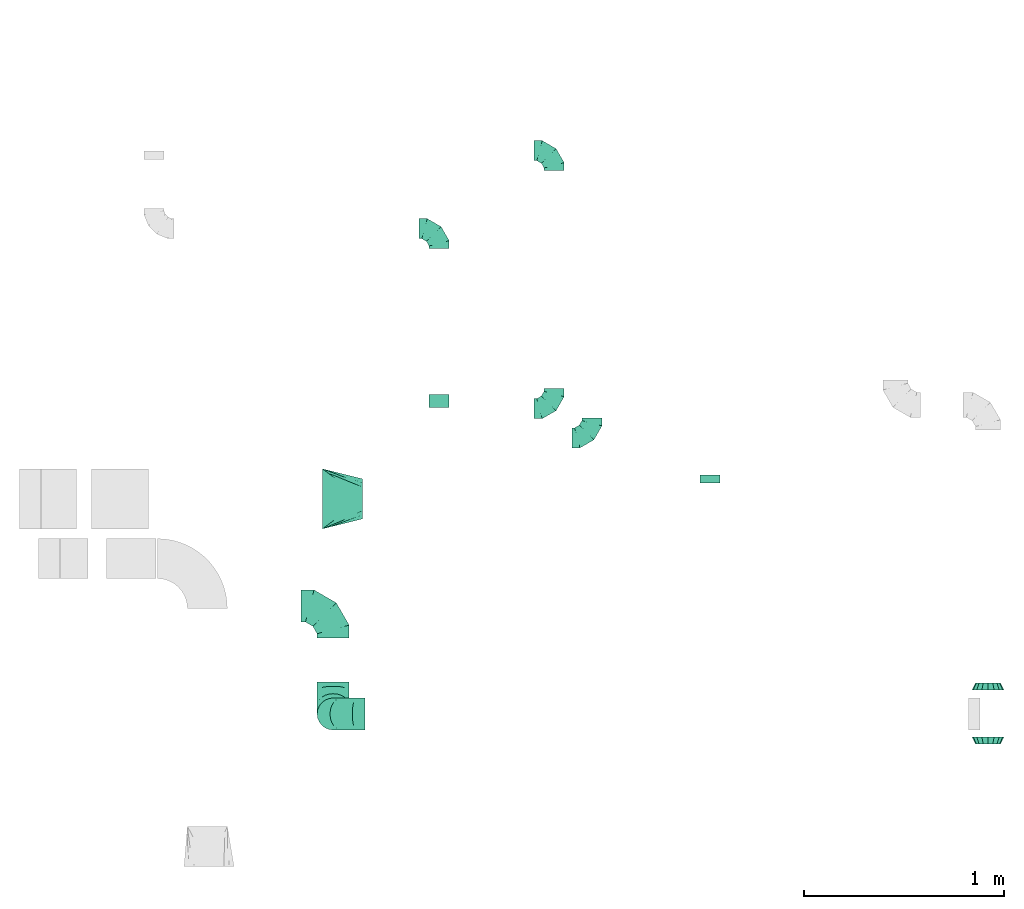
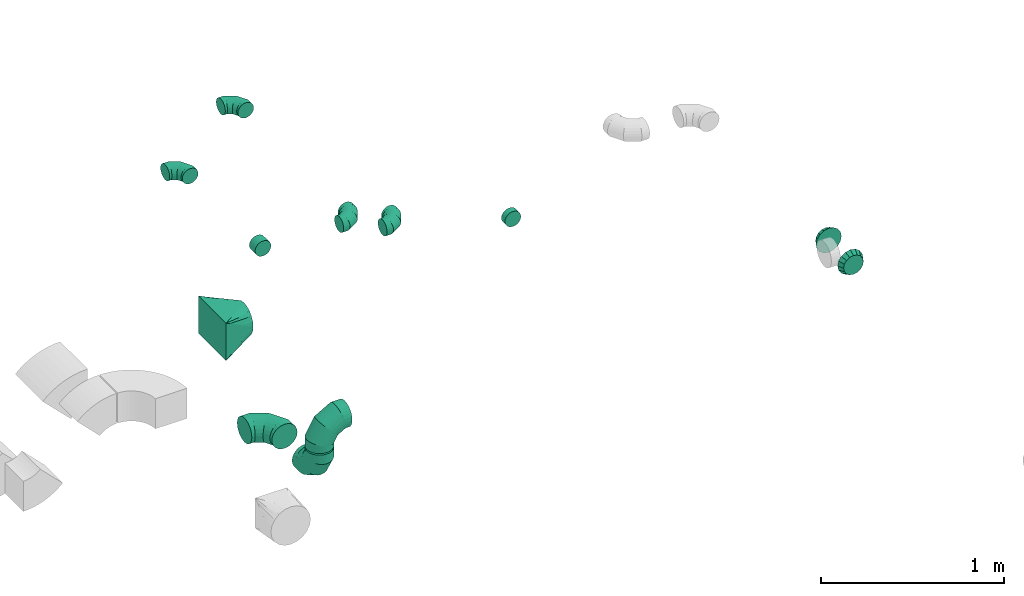
# One storey, part 37 of 44: 12 flow fittings.
"""IFC2X3 building model written with IfcOpenShell, lengths in millimetres."""

from ifc_helpers import new_model, entity, si_unit, converted_unit, derived_unit, direction, frame, origin, place, context, subcontext, project, spatial, faceted_brep, source, transform, mapped, material, type_object, type_shapes, element, save


model = new_model("IFC2X3")

# Units and contexts
model_context = context("Model", 3, precision=0.01, world=origin(), true_north=direction((6.12303176911189e-17, 1.0)))
body_context = subcontext(model_context, "Body", "Model", "MODEL_VIEW")
ifc_project = project(units=[si_unit("LENGTHUNIT", "METRE", prefix="MILLI"), si_unit("AREAUNIT", "SQUARE_METRE"), si_unit("VOLUMEUNIT", "CUBIC_METRE"), converted_unit("PLANEANGLEUNIT", "DEGREE", entity("IfcRatioMeasure", 0.0174532925199433), si_unit("PLANEANGLEUNIT", "RADIAN"), dimensions=[0, 0, 0, 0, 0, 0, 0]), si_unit("MASSUNIT", "GRAM", prefix="KILO"), derived_unit("MASSDENSITYUNIT", [(si_unit("MASSUNIT", "GRAM", prefix="KILO"), 1), (si_unit("LENGTHUNIT", "METRE"), -3)]), derived_unit("MOMENTOFINERTIAUNIT", [(si_unit("LENGTHUNIT", "METRE"), 4)]), si_unit("TIMEUNIT", "SECOND"), si_unit("FREQUENCYUNIT", "HERTZ"), si_unit("THERMODYNAMICTEMPERATUREUNIT", "DEGREE_CELSIUS"), derived_unit("THERMALTRANSMITTANCEUNIT", [(si_unit("MASSUNIT", "GRAM", prefix="KILO"), 1), (si_unit("THERMODYNAMICTEMPERATUREUNIT", "KELVIN"), -1), (si_unit("TIMEUNIT", "SECOND"), -3)]), derived_unit("VOLUMETRICFLOWRATEUNIT", [(si_unit("LENGTHUNIT", "METRE"), 3), (si_unit("TIMEUNIT", "SECOND"), -1)]), derived_unit("MASSFLOWRATEUNIT", [(si_unit("MASSUNIT", "GRAM", prefix="KILO"), 1), (si_unit("TIMEUNIT", "SECOND"), -1)]), derived_unit("ROTATIONALFREQUENCYUNIT", [(si_unit("TIMEUNIT", "SECOND"), -1)]), si_unit("ELECTRICCURRENTUNIT", "AMPERE"), si_unit("ELECTRICVOLTAGEUNIT", "VOLT"), si_unit("POWERUNIT", "WATT"), si_unit("FORCEUNIT", "NEWTON", prefix="KILO"), si_unit("ILLUMINANCEUNIT", "LUX"), si_unit("LUMINOUSFLUXUNIT", "LUMEN"), si_unit("LUMINOUSINTENSITYUNIT", "CANDELA"), derived_unit("USERDEFINED", [(si_unit("MASSUNIT", "GRAM", prefix="KILO"), -1), (si_unit("LENGTHUNIT", "METRE"), -2), (si_unit("TIMEUNIT", "SECOND"), 3), (si_unit("LUMINOUSFLUXUNIT", "LUMEN"), 1)]), derived_unit("LINEARVELOCITYUNIT", [(si_unit("LENGTHUNIT", "METRE"), 1), (si_unit("TIMEUNIT", "SECOND"), -1)]), si_unit("PRESSUREUNIT", "PASCAL"), derived_unit("USERDEFINED", [(si_unit("LENGTHUNIT", "METRE"), -2), (si_unit("MASSUNIT", "GRAM", prefix="KILO"), 1), (si_unit("TIMEUNIT", "SECOND"), -2)]), derived_unit("LINEARFORCEUNIT", [(si_unit("MASSUNIT", "GRAM", prefix="KILO"), 1), (si_unit("LENGTHUNIT", "METRE"), 1), (si_unit("TIMEUNIT", "SECOND"), -2), (si_unit("LENGTHUNIT", "METRE"), -1)]), derived_unit("PLANARFORCEUNIT", [(si_unit("MASSUNIT", "GRAM", prefix="KILO"), 1), (si_unit("LENGTHUNIT", "METRE"), 1), (si_unit("TIMEUNIT", "SECOND"), -2), (si_unit("LENGTHUNIT", "METRE"), -2)])], contexts=[model_context])

# Site, building, storey
site_placement = place(None, origin())
site = spatial("IfcSite", under=ifc_project, at=site_placement, CompositionType="ELEMENT")
building_placement = place(site_placement, origin())
building = spatial("IfcBuilding", under=site, at=building_placement, CompositionType="ELEMENT")
storey_placement = place(building_placement, frame((0.0, 0.0, 15900.0)))
storey = spatial("IfcBuildingStorey", under=building, at=storey_placement, CompositionType="ELEMENT", Elevation=15900.0)

# Flow fittings
ifc_material = material()
duct_fitting_type_1 = type_object("IfcDuctFittingType", PredefinedType="NOTDEFINED", material=ifc_material)
shared_shape_1 = source(origin(), body_context, "Body", "Brep", [
    faceted_brep([(-160.0, 0.0, -80.0), (-160.0, -20.71, -77.27), (-160.0, -40.0, -69.28), (-160.0, -56.57, -56.57), (-160.0, -69.28, -40.0), (-160.0, -77.27, -20.71), (-160.0, -80.0, 0.0), (-160.0, -77.27, 20.71), (-160.0, -69.28, 40.0), (-160.0, -56.57, 56.57), (-160.0, -40.0, 69.28), (-160.0, -20.71, 77.27), (-160.0, 0.0, 80.0), (-160.0, 20.71, 77.27), (-160.0, 40.0, 69.28), (-160.0, 56.57, 56.57), (-160.0, 69.28, 40.0), (-160.0, 77.27, 20.71), (-160.0, 80.0, 0.0), (-160.0, 77.27, -20.71), (-160.0, 69.28, -40.0), (-160.0, 56.57, -56.57), (-160.0, 40.0, -69.28), (-160.0, 20.71, -77.27), (-122.68, 20.71, 77.27), (-127.85, 40.0, 69.28), (-117.13, 0.0, 80.0), (-132.29, 56.57, 56.57), (-137.83, 77.27, 20.71), (-138.56, 80.0, 0.0), (-135.69, 69.28, 40.0), (-135.69, 69.28, -40.0), (-132.29, 56.57, -56.57), (-137.83, 77.27, -20.71), (-122.68, 20.71, -77.27), (-117.13, 0.0, -80.0), (-127.85, 40.0, -69.28), (-111.58, -20.71, -77.27), (-106.41, -40.0, -69.28), (-101.97, -56.57, -56.57), (-98.56, -69.28, -40.0), (-96.42, -77.27, -20.71), (-95.69, -80.0, 0.0), (-96.42, -77.27, 20.71), (-98.56, -69.28, 40.0), (-101.97, -56.57, 56.57), (-106.41, -40.0, 69.28), (-111.58, -20.71, 77.27), (-58.03, 58.03, 77.27), (-72.15, 72.15, 69.28), (-42.87, 42.87, 80.0), (-84.28, 84.28, 56.57), (-93.59, 93.59, 40.0), (-99.44, 99.44, 20.71), (-101.44, 101.44, 0.0), (-99.44, 99.44, -20.71), (-93.59, 93.59, -40.0), (-84.28, 84.28, -56.57), (-58.03, 58.03, -77.27), (-42.87, 42.87, -80.0), (-72.15, 72.15, -69.28), (-27.71, 27.71, -77.27), (-13.59, 13.59, -69.28), (-1.46, 1.46, -56.57), (7.85, -7.85, -40.0), (13.7, -13.7, -20.71), (15.69, -15.69, 0.0), (13.7, -13.7, 20.71), (7.85, -7.85, 40.0), (-1.46, 1.46, 56.57), (-13.59, 13.59, 69.28), (-27.71, 27.71, 77.27), (-20.71, 122.68, 77.27), (-40.0, 127.85, 69.28), (0.0, 117.13, 80.0), (-56.57, 132.29, 56.57), (-69.28, 135.69, 40.0), (-77.27, 137.83, 20.71), (-80.0, 138.56, 0.0), (-77.27, 137.83, -20.71), (-69.28, 135.69, -40.0), (-56.57, 132.29, -56.57), (-20.71, 122.68, -77.27), (0.0, 117.13, -80.0), (-40.0, 127.85, -69.28), (20.71, 111.58, -77.27), (40.0, 106.41, -69.28), (56.57, 101.97, -56.57), (69.28, 98.56, -40.0), (77.27, 96.42, -20.71), (80.0, 95.69, 0.0), (77.27, 96.42, 20.71), (69.28, 98.56, 40.0), (56.57, 101.97, 56.57), (40.0, 106.41, 69.28), (20.71, 111.58, 77.27), (-20.71, 160.0, -77.27), (-40.0, 160.0, -69.28), (-56.57, 160.0, -56.57), (-69.28, 160.0, -40.0), (-77.27, 160.0, -20.71), (-80.0, 160.0, 0.0), (-77.27, 160.0, 20.71), (-69.28, 160.0, 40.0), (-56.57, 160.0, 56.57), (-40.0, 160.0, 69.28), (-20.71, 160.0, 77.27), (0.0, 160.0, 80.0), (20.71, 160.0, 77.27), (40.0, 160.0, 69.28), (56.57, 160.0, 56.57), (69.28, 160.0, 40.0), (77.27, 160.0, 20.71), (80.0, 160.0, 0.0), (77.27, 160.0, -20.71), (69.28, 160.0, -40.0), (56.57, 160.0, -56.57), (40.0, 160.0, -69.28), (20.71, 160.0, -77.27), (0.0, 160.0, -80.0)], [[[0, 1, 2, 3, 4, 5, 6, 7, 8, 9, 10, 11, 12, 13, 14, 15, 16, 17, 18, 19, 20, 21, 22, 23]], [[24, 25, 14, 13]], [[26, 24, 13, 12]], [[14, 25, 27, 15]], [[28, 29, 18, 17]], [[30, 28, 17, 16]], [[15, 27, 30, 16]], [[20, 31, 32, 21]], [[33, 31, 20, 19]], [[18, 29, 33, 19]], [[34, 35, 0, 23]], [[36, 34, 23, 22]], [[32, 36, 22, 21]], [[1, 0, 35, 37]], [[2, 1, 37, 38]], [[3, 2, 38, 39]], [[5, 4, 40, 41]], [[6, 5, 41, 42]], [[39, 40, 4, 3]], [[6, 42, 43, 7]], [[7, 43, 44, 8]], [[8, 44, 45, 9]], [[9, 45, 46, 10]], [[10, 46, 47, 11]], [[26, 12, 11, 47]], [[48, 49, 25, 24]], [[50, 48, 24, 26]], [[27, 25, 49, 51]], [[52, 53, 28, 30]], [[51, 52, 30, 27]], [[29, 28, 53, 54]], [[55, 56, 31, 33]], [[54, 55, 33, 29]], [[32, 31, 56, 57]], [[58, 59, 35, 34]], [[60, 58, 34, 36]], [[57, 60, 36, 32]], [[37, 35, 59, 61]], [[38, 37, 61, 62]], [[39, 38, 62, 63]], [[41, 40, 64, 65]], [[42, 41, 65, 66]], [[63, 64, 40, 39]], [[43, 42, 66, 67]], [[44, 43, 67, 68]], [[68, 69, 45, 44]], [[46, 45, 69, 70]], [[47, 46, 70, 71]], [[26, 47, 71, 50]], [[72, 73, 49, 48]], [[74, 72, 48, 50]], [[51, 49, 73, 75]], [[76, 77, 53, 52]], [[75, 76, 52, 51]], [[54, 53, 77, 78]], [[79, 80, 56, 55]], [[78, 79, 55, 54]], [[57, 56, 80, 81]], [[82, 83, 59, 58]], [[84, 82, 58, 60]], [[81, 84, 60, 57]], [[61, 59, 83, 85]], [[62, 61, 85, 86]], [[63, 62, 86, 87]], [[65, 64, 88, 89]], [[66, 65, 89, 90]], [[87, 88, 64, 63]], [[67, 66, 90, 91]], [[68, 67, 91, 92]], [[92, 93, 69, 68]], [[70, 69, 93, 94]], [[71, 70, 94, 95]], [[50, 71, 95, 74]], [[96, 97, 98, 99, 100, 101, 102, 103, 104, 105, 106, 107, 108, 109, 110, 111, 112, 113, 114, 115, 116, 117, 118, 119]], [[72, 74, 107, 106]], [[73, 72, 106, 105]], [[75, 73, 105, 104]], [[77, 76, 103, 102]], [[78, 77, 102, 101]], [[75, 104, 103, 76]], [[78, 101, 100, 79]], [[79, 100, 99, 80]], [[80, 99, 98, 81]], [[84, 97, 96, 82]], [[82, 96, 119, 83]], [[84, 81, 98, 97]], [[118, 117, 86, 85]], [[119, 118, 85, 83]], [[116, 87, 86, 117]], [[88, 115, 114, 89]], [[89, 114, 113, 90]], [[115, 88, 87, 116]], [[112, 111, 92, 91]], [[113, 112, 91, 90]], [[111, 110, 93, 92]], [[95, 94, 109, 108]], [[74, 95, 108, 107]], [[110, 109, 94, 93]]]),
])
type_shapes(duct_fitting_type_1, [shared_shape_1])
for number, where, z_axis, x_axis in (
    (1, (69509.84, 9338.57, 2935.0), (0.0, 0.0, 1.0), (0.0, 1.0, 0.0)),
    (2, (69509.84, 8798.57, 2935.0), (-1.0, 0.0, 0.0), (0.0, -1.0, 0.0)),
    (3, (69509.84, 8798.57, 3265.0), (0.0, 1.0, 0.0), (0.0, 0.0, 1.0)),
):
    element("IfcFlowFitting", number, at=place(storey_placement, frame(where, z_axis=z_axis, x_axis=x_axis)), inside=storey, type_object=duct_fitting_type_1, material=ifc_material, context=body_context, shape_type="MappedRepresentation", body=[
        mapped(shared_shape_1, transform((0.0, 0.0, 0.0), scale=1.0)),
    ])
duct_fitting_type_2 = type_object("IfcDuctFittingType", PredefinedType="NOTDEFINED", material=ifc_material)
shared_shape_2 = source(origin(), body_context, "Body", "Brep", [
    faceted_brep([(-100.0, 0.0, -50.0), (-100.0, -12.94, -48.3), (-100.0, -25.0, -43.3), (-100.0, -35.36, -35.36), (-100.0, -43.3, -25.0), (-100.0, -48.3, -12.94), (-100.0, -50.0, 0.0), (-100.0, -48.3, 12.94), (-100.0, -43.3, 25.0), (-100.0, -35.36, 35.36), (-100.0, -25.0, 43.3), (-100.0, -12.94, 48.3), (-100.0, 0.0, 50.0), (-100.0, 12.94, 48.3), (-100.0, 25.0, 43.3), (-100.0, 35.36, 35.36), (-100.0, 43.3, 25.0), (-100.0, 48.3, 12.94), (-100.0, 50.0, 0.0), (-100.0, 48.3, -12.94), (-100.0, 43.3, -25.0), (-100.0, 35.36, -35.36), (-100.0, 25.0, -43.3), (-100.0, 12.94, -48.3), (-76.67, 12.94, 48.3), (-79.9, 25.0, 43.3), (-73.21, 0.0, 50.0), (-82.68, 35.36, 35.36), (-86.15, 48.3, 12.94), (-86.6, 50.0, 0.0), (-84.81, 43.3, 25.0), (-84.81, 43.3, -25.0), (-82.68, 35.36, -35.36), (-86.15, 48.3, -12.94), (-76.67, 12.94, -48.3), (-73.21, 0.0, -50.0), (-79.9, 25.0, -43.3), (-69.74, -12.94, -48.3), (-66.51, -25.0, -43.3), (-63.73, -35.36, -35.36), (-61.6, -43.3, -25.0), (-60.26, -48.3, -12.94), (-59.81, -50.0, 0.0), (-60.26, -48.3, 12.94), (-61.6, -43.3, 25.0), (-63.73, -35.36, 35.36), (-66.51, -25.0, 43.3), (-69.74, -12.94, 48.3), (-36.27, 36.27, 48.3), (-45.1, 45.1, 43.3), (-26.79, 26.79, 50.0), (-52.68, 52.68, 35.36), (-58.49, 58.49, 25.0), (-62.15, 62.15, 12.94), (-63.4, 63.4, 0.0), (-62.15, 62.15, -12.94), (-58.49, 58.49, -25.0), (-52.68, 52.68, -35.36), (-36.27, 36.27, -48.3), (-26.79, 26.79, -50.0), (-45.1, 45.1, -43.3), (-17.32, 17.32, -48.3), (-8.49, 8.49, -43.3), (-0.91, 0.91, -35.36), (4.9, -4.9, -25.0), (8.56, -8.56, -12.94), (9.81, -9.81, 0.0), (8.56, -8.56, 12.94), (4.9, -4.9, 25.0), (-0.91, 0.91, 35.36), (-8.49, 8.49, 43.3), (-17.32, 17.32, 48.3), (-12.94, 76.67, 48.3), (-25.0, 79.9, 43.3), (0.0, 73.21, 50.0), (-35.36, 82.68, 35.36), (-43.3, 84.81, 25.0), (-48.3, 86.15, 12.94), (-50.0, 86.6, 0.0), (-48.3, 86.15, -12.94), (-43.3, 84.81, -25.0), (-35.36, 82.68, -35.36), (-12.94, 76.67, -48.3), (0.0, 73.21, -50.0), (-25.0, 79.9, -43.3), (12.94, 69.74, -48.3), (25.0, 66.51, -43.3), (35.36, 63.73, -35.36), (43.3, 61.6, -25.0), (48.3, 60.26, -12.94), (50.0, 59.81, 0.0), (48.3, 60.26, 12.94), (43.3, 61.6, 25.0), (35.36, 63.73, 35.36), (25.0, 66.51, 43.3), (12.94, 69.74, 48.3), (-12.94, 100.0, -48.3), (-25.0, 100.0, -43.3), (-35.36, 100.0, -35.36), (-43.3, 100.0, -25.0), (-48.3, 100.0, -12.94), (-50.0, 100.0, 0.0), (-48.3, 100.0, 12.94), (-43.3, 100.0, 25.0), (-35.36, 100.0, 35.36), (-25.0, 100.0, 43.3), (-12.94, 100.0, 48.3), (0.0, 100.0, 50.0), (12.94, 100.0, 48.3), (25.0, 100.0, 43.3), (35.36, 100.0, 35.36), (43.3, 100.0, 25.0), (48.3, 100.0, 12.94), (50.0, 100.0, 0.0), (48.3, 100.0, -12.94), (43.3, 100.0, -25.0), (35.36, 100.0, -35.36), (25.0, 100.0, -43.3), (12.94, 100.0, -48.3), (0.0, 100.0, -50.0)], [[[0, 1, 2, 3, 4, 5, 6, 7, 8, 9, 10, 11, 12, 13, 14, 15, 16, 17, 18, 19, 20, 21, 22, 23]], [[24, 25, 14, 13]], [[26, 24, 13, 12]], [[14, 25, 27, 15]], [[28, 29, 18, 17]], [[30, 28, 17, 16]], [[15, 27, 30, 16]], [[20, 31, 32, 21]], [[33, 31, 20, 19]], [[18, 29, 33, 19]], [[34, 35, 0, 23]], [[36, 34, 23, 22]], [[32, 36, 22, 21]], [[2, 1, 37, 38]], [[3, 2, 38, 39]], [[0, 35, 37, 1]], [[5, 4, 40, 41]], [[6, 5, 41, 42]], [[3, 39, 40, 4]], [[6, 42, 43, 7]], [[7, 43, 44, 8]], [[8, 44, 45, 9]], [[10, 46, 47, 11]], [[11, 47, 26, 12]], [[10, 9, 45, 46]], [[48, 49, 25, 24]], [[50, 48, 24, 26]], [[27, 25, 49, 51]], [[52, 53, 28, 30]], [[51, 52, 30, 27]], [[29, 28, 53, 54]], [[55, 56, 31, 33]], [[54, 55, 33, 29]], [[57, 32, 31, 56]], [[58, 59, 35, 34]], [[60, 58, 34, 36]], [[57, 60, 36, 32]], [[37, 35, 59, 61]], [[38, 37, 61, 62]], [[39, 38, 62, 63]], [[41, 40, 64, 65]], [[42, 41, 65, 66]], [[63, 64, 40, 39]], [[43, 42, 66, 67]], [[44, 43, 67, 68]], [[68, 69, 45, 44]], [[46, 45, 69, 70]], [[47, 46, 70, 71]], [[26, 47, 71, 50]], [[72, 73, 49, 48]], [[74, 72, 48, 50]], [[51, 49, 73, 75]], [[76, 77, 53, 52]], [[75, 76, 52, 51]], [[54, 53, 77, 78]], [[79, 80, 56, 55]], [[78, 79, 55, 54]], [[81, 57, 56, 80]], [[82, 83, 59, 58]], [[84, 82, 58, 60]], [[81, 84, 60, 57]], [[61, 59, 83, 85]], [[62, 61, 85, 86]], [[63, 62, 86, 87]], [[65, 64, 88, 89]], [[66, 65, 89, 90]], [[87, 88, 64, 63]], [[67, 66, 90, 91]], [[68, 67, 91, 92]], [[92, 93, 69, 68]], [[70, 69, 93, 94]], [[71, 70, 94, 95]], [[50, 71, 95, 74]], [[96, 97, 98, 99, 100, 101, 102, 103, 104, 105, 106, 107, 108, 109, 110, 111, 112, 113, 114, 115, 116, 117, 118, 119]], [[72, 74, 107, 106]], [[73, 72, 106, 105]], [[75, 73, 105, 104]], [[77, 76, 103, 102]], [[78, 77, 102, 101]], [[75, 104, 103, 76]], [[78, 101, 100, 79]], [[79, 100, 99, 80]], [[80, 99, 98, 81]], [[96, 119, 83, 82]], [[97, 96, 82, 84]], [[84, 81, 98, 97]], [[83, 119, 118, 85]], [[85, 118, 117, 86]], [[86, 117, 116, 87]], [[88, 115, 114, 89]], [[89, 114, 113, 90]], [[87, 116, 115, 88]], [[91, 90, 113, 112]], [[92, 91, 112, 111]], [[93, 92, 111, 110]], [[95, 94, 109, 108]], [[74, 95, 108, 107]], [[110, 109, 94, 93]]]),
])
type_shapes(duct_fitting_type_2, [shared_shape_2])
for number, where in (
    (4, (70803.81, 10179.05, 3300.0)),
    (5, (70614.82, 10325.19, 3300.0)),
):
    element("IfcFlowFitting", number, at=place(storey_placement, frame(where)), inside=storey, type_object=duct_fitting_type_2, material=ifc_material, context=body_context, shape_type="MappedRepresentation", body=[
        mapped(shared_shape_2, transform((0.0, 0.0, 0.0), scale=1.0)),
    ])
for number, where, z_axis, x_axis in (
    (6, (70614.82, 11615.19, 3300.0), (0.0, 0.0, 1.0), (0.0, 1.0, 0.0)),
    (7, (70039.82, 11225.19, 3300.0), (0.0, 0.0, 1.0), (0.0, 1.0, 0.0)),
):
    element("IfcFlowFitting", number, at=place(storey_placement, frame(where, z_axis=z_axis, x_axis=x_axis)), inside=storey, type_object=duct_fitting_type_2, material=ifc_material, context=body_context, shape_type="MappedRepresentation", body=[
        mapped(shared_shape_2, transform((0.0, 0.0, 0.0), scale=1.0)),
    ])
duct_fitting_type_3 = type_object("IfcDuctFittingType", PredefinedType="NOTDEFINED", material=ifc_material)
shared_shape_3 = source(origin(), body_context, "Body", "Brep", [
    faceted_brep([(35.0, -57.74, 23.92), (35.0, -60.12, 11.96), (35.0, -62.5, 0.0), (35.0, -60.12, -11.96), (35.0, -57.74, -23.92), (35.0, -50.97, -34.06), (35.0, -44.19, -44.19), (35.0, -34.06, -50.97), (35.0, -23.92, -57.74), (35.0, -11.96, -60.12), (35.0, 0.0, -62.5), (35.0, 11.96, -60.12), (35.0, 23.92, -57.74), (35.0, 34.06, -50.97), (35.0, 44.19, -44.19), (35.0, 50.97, -34.06), (35.0, 57.74, -23.92), (35.0, 60.12, -11.96), (35.0, 62.5, 0.0), (35.0, 60.12, 11.96), (35.0, 57.74, 23.92), (35.0, 50.97, 34.06), (35.0, 44.19, 44.19), (35.0, 34.06, 50.97), (35.0, 23.92, 57.74), (35.0, 11.96, 60.12), (35.0, 0.0, 62.5), (35.0, -11.96, 60.12), (35.0, -23.92, 57.74), (35.0, -34.06, 50.97), (35.0, -44.19, 44.19), (35.0, -50.97, 34.06), (0.0, -80.0, 0.0), (0.0, -77.45, 12.81), (0.0, -73.91, 30.61), (0.0, -65.24, 43.59), (0.0, -56.57, 56.57), (0.0, -43.59, 65.24), (0.0, -30.61, 73.91), (0.0, -12.81, 77.45), (0.0, 0.0, 80.0), (0.0, 12.81, 77.45), (0.0, 30.61, 73.91), (0.0, 43.59, 65.24), (0.0, 56.57, 56.57), (0.0, 65.24, 43.59), (0.0, 73.91, 30.61), (0.0, 77.45, 12.81), (0.0, 80.0, 0.0), (0.0, 77.45, -12.81), (0.0, 73.91, -30.61), (0.0, 65.24, -43.59), (0.0, 56.57, -56.57), (0.0, 43.59, -65.24), (0.0, 30.61, -73.91), (0.0, 12.81, -77.45), (0.0, 0.0, -80.0), (0.0, -12.81, -77.45), (0.0, -30.61, -73.91), (0.0, -43.59, -65.24), (0.0, -56.57, -56.57), (0.0, -65.24, -43.59), (0.0, -73.91, -30.61), (0.0, -77.45, -12.81)], [[[0, 1, 2, 3, 4, 5, 6, 7, 8, 9, 10, 11, 12, 13, 14, 15, 16, 17, 18, 19, 20, 21, 22, 23, 24, 25, 26, 27, 28, 29, 30, 31]], [[32, 33, 34, 35, 36, 37, 38, 39, 40, 41, 42, 43, 44, 45, 46, 47, 48, 49, 50, 51, 52, 53, 54, 55, 56, 57, 58, 59, 60, 61, 62, 63]], [[24, 23, 22, 44, 43, 42]], [[20, 46, 45, 44, 22, 21]], [[42, 41, 40, 26, 25, 24]], [[47, 46, 20, 19, 18, 48]], [[0, 31, 30, 36, 35, 34]], [[28, 38, 37, 36, 30, 29]], [[34, 33, 32, 2, 1, 0]], [[39, 38, 28, 27, 26, 40]], [[8, 7, 6, 60, 59, 58]], [[4, 62, 61, 60, 6, 5]], [[58, 57, 56, 10, 9, 8]], [[63, 62, 4, 3, 2, 32]], [[16, 15, 14, 52, 51, 50]], [[12, 54, 53, 52, 14, 13]], [[50, 49, 48, 18, 17, 16]], [[55, 54, 12, 11, 10, 56]]]),
])
type_shapes(duct_fitting_type_3, [shared_shape_3])
for number, where, z_axis, x_axis in (
    (8, (72784.16, 8918.57, 3250.0), (0.0, 0.0, 1.0), (0.0, 1.0, 0.0)),
    (9, (72784.16, 8683.57, 3250.0), (0.0, 0.0, 1.0), (0.0, -1.0, 0.0)),
):
    element("IfcFlowFitting", number, at=place(storey_placement, frame(where, z_axis=z_axis, x_axis=x_axis)), inside=storey, type_object=duct_fitting_type_3, material=ifc_material, context=body_context, shape_type="MappedRepresentation", body=[
        mapped(shared_shape_3, transform((0.0, 0.0, 0.0), scale=1.0)),
    ])
duct_fitting_type_4 = type_object("IfcDuctFittingType", PredefinedType="NOTDEFINED", material=ifc_material)
shared_shape_4 = source(origin(), body_context, "Body", "Brep", [
    faceted_brep([(20.0, 0.0, -50.0), (20.0, 12.94, -48.3), (20.0, 25.0, -43.3), (20.0, 35.36, -35.36), (20.0, 43.3, -25.0), (20.0, 48.3, -12.94), (20.0, 50.0, 0.0), (20.0, 48.3, 12.94), (20.0, 43.3, 25.0), (20.0, 35.36, 35.36), (20.0, 25.0, 43.3), (20.0, 12.94, 48.3), (20.0, 0.0, 50.0), (20.0, -12.94, 48.3), (20.0, -25.0, 43.3), (20.0, -35.36, 35.36), (20.0, -43.3, 25.0), (20.0, -48.3, 12.94), (20.0, -50.0, 0.0), (20.0, -48.3, -12.94), (20.0, -43.3, -25.0), (20.0, -35.36, -35.36), (20.0, -25.0, -43.3), (20.0, -12.94, -48.3), (0.0, 0.0, 50.0), (-43.9, 0.0, 50.0), (-43.9, -12.94, 48.3), (0.0, -12.94, 48.3), (-43.9, -25.0, 43.3), (0.0, -25.0, 43.3), (0.0, -35.36, 35.36), (-43.9, -35.36, 35.36), (0.0, -43.3, 25.0), (-43.9, -43.3, 25.0), (-43.9, -48.3, 12.94), (0.0, -48.3, 12.94), (-43.9, -50.0, 0.0), (0.0, -50.0, 0.0), (-43.9, -48.3, -12.94), (0.0, -48.3, -12.94), (-43.9, -43.3, -25.0), (0.0, -43.3, -25.0), (0.0, -35.36, -35.36), (-43.9, -35.36, -35.36), (0.0, -25.0, -43.3), (-43.9, -25.0, -43.3), (-43.9, -12.94, -48.3), (0.0, -12.94, -48.3), (-43.9, 0.0, -50.0), (0.0, 0.0, -50.0), (-43.9, 12.94, -48.3), (0.0, 12.94, -48.3), (-43.9, 25.0, -43.3), (0.0, 25.0, -43.3), (0.0, 35.36, -35.36), (-43.9, 35.36, -35.36), (0.0, 43.3, -25.0), (-43.9, 43.3, -25.0), (-43.9, 48.3, -12.94), (0.0, 48.3, -12.94), (-43.9, 50.0, 0.0), (0.0, 50.0, 0.0), (-43.9, 48.3, 12.94), (0.0, 48.3, 12.94), (-43.9, 43.3, 25.0), (0.0, 43.3, 25.0), (0.0, 35.36, 35.36), (-43.9, 35.36, 35.36), (0.0, 25.0, 43.3), (-43.9, 25.0, 43.3), (-43.9, 12.94, 48.3), (0.0, 12.94, 48.3)], [[[0, 1, 2, 3, 4, 5, 6, 7, 8, 9, 10, 11, 12, 13, 14, 15, 16, 17, 18, 19, 20, 21, 22, 23]], [[13, 12, 24, 25, 26, 27]], [[14, 13, 27, 26, 28, 29]], [[30, 15, 14, 29, 28, 31]], [[17, 16, 32, 33, 34, 35]], [[18, 17, 35, 34, 36, 37]], [[32, 16, 15, 30, 31, 33]], [[19, 18, 37, 36, 38, 39]], [[20, 19, 39, 38, 40, 41]], [[42, 21, 20, 41, 40, 43]], [[23, 22, 44, 45, 46, 47]], [[0, 23, 47, 46, 48, 49]], [[44, 22, 21, 42, 43, 45]], [[1, 0, 49, 48, 50, 51]], [[2, 1, 51, 50, 52, 53]], [[54, 3, 2, 53, 52, 55]], [[5, 4, 56, 57, 58, 59]], [[6, 5, 59, 58, 60, 61]], [[56, 4, 3, 54, 55, 57]], [[7, 6, 61, 60, 62, 63]], [[8, 7, 63, 62, 64, 65]], [[66, 9, 8, 65, 64, 67]], [[11, 10, 68, 69, 70, 71]], [[12, 11, 71, 70, 25, 24]], [[68, 10, 9, 66, 67, 69]], [[46, 45, 43, 40, 38, 36, 34, 33, 31, 28, 26, 25, 70, 69, 67, 64, 62, 60, 58, 57, 55, 52, 50, 48]]]),
])
type_shapes(duct_fitting_type_4, [shared_shape_4])
flow_fitting_1_placement = place(storey_placement, frame((70039.82, 10375.19, 3300.0), z_axis=(0.0, 0.0, -1.0), x_axis=(0.0, 1.0, 0.0)))
element("IfcFlowFitting", 10, at=flow_fitting_1_placement, inside=storey, type_object=duct_fitting_type_4, material=ifc_material, context=body_context, shape_type="MappedRepresentation", body=[
    mapped(shared_shape_4, transform((0.0, 0.0, 0.0), scale=1.0)),
])
duct_fitting_type_5 = type_object("IfcDuctFittingType", PredefinedType="NOTDEFINED", material=ifc_material)
shared_shape_5 = source(origin(), body_context, "Body", "Brep", [
    faceted_brep([(20.0, 0.0, -50.0), (20.0, 12.94, -48.3), (20.0, 25.0, -43.3), (20.0, 35.36, -35.36), (20.0, 43.3, -25.0), (20.0, 48.3, -12.94), (20.0, 50.0, 0.0), (20.0, 48.3, 12.94), (20.0, 43.3, 25.0), (20.0, 35.36, 35.36), (20.0, 25.0, 43.3), (20.0, 12.94, 48.3), (20.0, 0.0, 50.0), (20.0, -12.94, 48.3), (20.0, -25.0, 43.3), (20.0, -35.36, 35.36), (20.0, -43.3, 25.0), (20.0, -48.3, 12.94), (20.0, -50.0, 0.0), (20.0, -48.3, -12.94), (20.0, -43.3, -25.0), (20.0, -35.36, -35.36), (20.0, -25.0, -43.3), (20.0, -12.94, -48.3), (0.0, 0.0, 50.0), (-19.49, 0.0, 50.0), (-19.49, -12.94, 48.3), (0.0, -12.94, 48.3), (-19.49, -25.0, 43.3), (0.0, -25.0, 43.3), (0.0, -35.36, 35.36), (-19.49, -35.36, 35.36), (0.0, -43.3, 25.0), (-19.49, -43.3, 25.0), (-19.49, -48.3, 12.94), (0.0, -48.3, 12.94), (-19.49, -50.0, 0.0), (0.0, -50.0, 0.0), (-19.49, -48.3, -12.94), (0.0, -48.3, -12.94), (-19.49, -43.3, -25.0), (0.0, -43.3, -25.0), (0.0, -35.36, -35.36), (-19.49, -35.36, -35.36), (0.0, -25.0, -43.3), (-19.49, -25.0, -43.3), (-19.49, -12.94, -48.3), (0.0, -12.94, -48.3), (-19.49, 0.0, -50.0), (0.0, 0.0, -50.0), (-19.49, 12.94, -48.3), (0.0, 12.94, -48.3), (-19.49, 25.0, -43.3), (0.0, 25.0, -43.3), (0.0, 35.36, -35.36), (-19.49, 35.36, -35.36), (0.0, 43.3, -25.0), (-19.49, 43.3, -25.0), (-19.49, 48.3, -12.94), (0.0, 48.3, -12.94), (-19.49, 50.0, 0.0), (0.0, 50.0, 0.0), (-19.49, 48.3, 12.94), (0.0, 48.3, 12.94), (-19.49, 43.3, 25.0), (0.0, 43.3, 25.0), (0.0, 35.36, 35.36), (-19.49, 35.36, 35.36), (0.0, 25.0, 43.3), (-19.49, 25.0, 43.3), (-19.49, 12.94, 48.3), (0.0, 12.94, 48.3)], [[[0, 1, 2, 3, 4, 5, 6, 7, 8, 9, 10, 11, 12, 13, 14, 15, 16, 17, 18, 19, 20, 21, 22, 23]], [[13, 12, 24, 25, 26, 27]], [[14, 13, 27, 26, 28, 29]], [[30, 15, 14, 29, 28, 31]], [[17, 16, 32, 33, 34, 35]], [[18, 17, 35, 34, 36, 37]], [[32, 16, 15, 30, 31, 33]], [[19, 18, 37, 36, 38, 39]], [[20, 19, 39, 38, 40, 41]], [[42, 21, 20, 41, 40, 43]], [[23, 22, 44, 45, 46, 47]], [[0, 23, 47, 46, 48, 49]], [[44, 22, 21, 42, 43, 45]], [[1, 0, 49, 48, 50, 51]], [[2, 1, 51, 50, 52, 53]], [[54, 3, 2, 53, 52, 55]], [[5, 4, 56, 57, 58, 59]], [[6, 5, 59, 58, 60, 61]], [[56, 4, 3, 54, 55, 57]], [[7, 6, 61, 60, 62, 63]], [[8, 7, 63, 62, 64, 65]], [[66, 9, 8, 65, 64, 67]], [[11, 10, 68, 69, 70, 71]], [[12, 11, 71, 70, 25, 24]], [[68, 10, 9, 66, 67, 69]], [[46, 45, 43, 40, 38, 36, 34, 33, 31, 28, 26, 25, 70, 69, 67, 64, 62, 60, 58, 57, 55, 52, 50, 48]]]),
])
type_shapes(duct_fitting_type_5, [shared_shape_5])
flow_fitting_2_placement = place(storey_placement, frame((71394.92, 9974.07, 3250.0), z_axis=(0.0, 0.0, -1.0), x_axis=(0.0, 1.0, 0.0)))
element("IfcFlowFitting", 11, at=flow_fitting_2_placement, inside=storey, type_object=duct_fitting_type_5, material=ifc_material, context=body_context, shape_type="MappedRepresentation", body=[
    mapped(shared_shape_5, transform((0.0, 0.0, 0.0), scale=1.0)),
])
duct_fitting_type_6 = type_object("IfcDuctFittingType", PredefinedType="NOTDEFINED", material=ifc_material)
shared_shape_6 = source(origin(), body_context, "Body", "Brep", [
    faceted_brep([(200.0, 30.9, 95.11), (200.0, 19.08, 96.98), (200.0, 9.54, 98.49), (200.0, 4.77, 99.24), (200.0, 0.0, 100.0), (200.0, -4.77, 99.24), (200.0, -9.54, 98.49), (200.0, -19.08, 96.98), (200.0, -30.9, 95.11), (200.0, -44.84, 88.0), (200.0, -58.78, 80.9), (200.0, -69.84, 69.84), (200.0, -80.9, 58.78), (200.0, -88.0, 44.84), (200.0, -95.11, 30.9), (200.0, -96.98, 19.08), (200.0, -98.49, 9.54), (200.0, -99.24, 4.77), (200.0, -100.0, 0.0), (200.0, -99.24, -4.77), (200.0, -98.49, -9.54), (200.0, -96.98, -19.08), (200.0, -95.11, -30.9), (200.0, -88.0, -44.84), (200.0, -80.9, -58.78), (200.0, -69.84, -69.84), (200.0, -58.78, -80.9), (200.0, -44.84, -88.0), (200.0, -30.9, -95.11), (200.0, -19.08, -96.98), (200.0, -9.54, -98.49), (200.0, -4.77, -99.24), (200.0, 0.0, -100.0), (200.0, 4.77, -99.24), (200.0, 9.54, -98.49), (200.0, 19.08, -96.98), (200.0, 30.9, -95.11), (200.0, 44.84, -88.0), (200.0, 58.78, -80.9), (200.0, 69.84, -69.84), (200.0, 80.9, -58.78), (200.0, 88.0, -44.84), (200.0, 95.11, -30.9), (200.0, 96.98, -19.08), (200.0, 98.49, -9.54), (200.0, 99.24, -4.77), (200.0, 100.0, 0.0), (200.0, 99.24, 4.77), (200.0, 98.49, 9.54), (200.0, 96.98, 19.08), (200.0, 95.11, 30.9), (200.0, 88.0, 44.84), (200.0, 80.9, 58.78), (200.0, 69.84, 69.84), (200.0, 58.78, 80.9), (200.0, 44.84, 88.0), (0.0, -150.0, 125.0), (0.0, 150.0, 125.0), (0.0, 150.0, -125.0), (0.0, -150.0, -125.0), (104.11, -71.91, 111.99), (100.0, -108.15, 99.93), (26.03, -130.48, 121.75), (78.09, -91.44, 115.24), (52.06, -110.96, 118.49), (188.01, -8.99, 101.5), (176.03, -17.98, 103.0), (152.06, -35.96, 105.99), (128.09, -53.94, 108.99), (52.06, -136.99, 92.46), (78.09, -130.48, 76.2), (104.11, -123.97, 59.93), (128.09, -117.98, 44.95), (152.06, -111.99, 29.96), (176.03, -105.99, 14.98), (188.01, -103.0, 7.49), (26.03, -143.49, 108.73), (26.03, -143.49, -108.73), (52.06, -136.99, -92.46), (78.09, -130.48, -76.2), (104.11, -123.97, -59.93), (128.09, -117.98, -44.95), (152.06, -111.99, -29.96), (176.03, -105.99, -14.98), (188.01, -103.0, -7.49), (100.0, -112.43, -95.65), (52.06, -110.96, -118.49), (78.09, -91.44, -115.24), (104.11, -71.91, -111.99), (128.09, -53.94, -108.99), (152.06, -35.96, -105.99), (176.03, -17.98, -103.0), (188.01, -8.99, -101.5), (26.03, -130.48, -121.75), (26.03, 130.48, -121.75), (52.06, 110.96, -118.49), (78.09, 91.44, -115.24), (104.11, 71.91, -111.99), (128.09, 53.94, -108.99), (152.06, 35.96, -105.99), (176.03, 17.98, -103.0), (188.01, 8.99, -101.5), (100.0, 108.15, -99.93), (52.06, 136.99, -92.46), (78.09, 130.48, -76.2), (104.11, 123.97, -59.93), (128.09, 117.98, -44.95), (152.06, 111.99, -29.96), (176.03, 105.99, -14.98), (188.01, 103.0, -7.49), (26.03, 143.49, -108.73), (26.03, 143.49, 108.73), (52.06, 136.99, 92.46), (78.09, 130.48, 76.2), (104.11, 123.97, 59.93), (128.09, 117.98, 44.95), (152.06, 111.99, 29.96), (176.03, 105.99, 14.98), (188.01, 103.0, 7.49), (100.0, 112.43, 95.65), (52.06, 110.96, 118.49), (78.09, 91.44, 115.24), (104.11, 71.91, 111.99), (128.09, 53.94, 108.99), (152.06, 35.96, 105.99), (176.03, 17.98, 103.0), (188.01, 8.99, 101.5), (26.03, 130.48, 121.75)], [[[0, 1, 2, 3, 4, 5, 6, 7, 8, 9, 10, 11, 12, 13, 14, 15, 16, 17, 18, 19, 20, 21, 22, 23, 24, 25, 26, 27, 28, 29, 30, 31, 32, 33, 34, 35, 36, 37, 38, 39, 40, 41, 42, 43, 44, 45, 46, 47, 48, 49, 50, 51, 52, 53, 54, 55]], [[56, 57, 58, 59]], [[60, 9, 8]], [[56, 61, 62]], [[9, 60, 63, 64]], [[65, 66, 67, 68, 60, 8, 7, 6, 5, 4]], [[62, 61, 10]], [[13, 69, 70, 71]], [[64, 10, 9]], [[14, 71, 72, 73, 74, 75, 18, 17, 16, 15]], [[12, 76, 69]], [[71, 14, 13]], [[61, 76, 11]], [[10, 64, 62]], [[76, 12, 11]], [[10, 61, 11]], [[61, 56, 76]], [[69, 13, 12]], [[75, 74, 73, 72, 71, 70, 69, 76, 56, 59, 77, 78, 79, 80, 81, 82, 83, 84, 18]], [[80, 23, 22]], [[59, 85, 77]], [[23, 80, 79, 78]], [[84, 83, 82, 81, 80, 22, 21, 20, 19, 18]], [[77, 85, 24]], [[27, 86, 87, 88]], [[78, 24, 23]], [[28, 88, 89, 90, 91, 92, 32, 31, 30, 29]], [[26, 93, 86]], [[88, 28, 27]], [[85, 93, 25]], [[24, 78, 77]], [[93, 26, 25]], [[24, 85, 25]], [[85, 59, 93]], [[86, 27, 26]], [[92, 91, 90, 89, 88, 87, 86, 93, 59, 58, 94, 95, 96, 97, 98, 99, 100, 101, 32]], [[97, 37, 36]], [[58, 102, 94]], [[37, 97, 96, 95]], [[101, 100, 99, 98, 97, 36, 35, 34, 33, 32]], [[94, 102, 38]], [[41, 103, 104, 105]], [[95, 38, 37]], [[42, 105, 106, 107, 108, 109, 46, 45, 44, 43]], [[40, 110, 103]], [[105, 42, 41]], [[102, 110, 39]], [[38, 95, 94]], [[110, 40, 39]], [[38, 102, 39]], [[102, 58, 110]], [[103, 41, 40]], [[58, 57, 111, 112, 113, 114, 115, 116, 117, 118, 46, 109, 108, 107, 106, 105, 104, 103, 110]], [[114, 51, 50]], [[57, 119, 111]], [[51, 114, 113, 112]], [[118, 117, 116, 115, 114, 50, 49, 48, 47, 46]], [[111, 119, 52]], [[55, 120, 121, 122]], [[112, 52, 51]], [[0, 122, 123, 124, 125, 126, 4, 3, 2, 1]], [[54, 127, 120]], [[122, 0, 55]], [[119, 127, 53]], [[52, 112, 111]], [[127, 54, 53]], [[52, 119, 53]], [[119, 57, 127]], [[120, 55, 54]], [[57, 56, 62, 64, 63, 60, 68, 67, 66, 65, 4, 126, 125, 124, 123, 122, 121, 120, 127]]]),
])
type_shapes(duct_fitting_type_6, [shared_shape_6])
flow_fitting_3_placement = place(storey_placement, frame((69456.48, 9874.07, 3250.0)))
element("IfcFlowFitting", 12, at=flow_fitting_3_placement, inside=storey, type_object=duct_fitting_type_6, material=ifc_material, context=body_context, shape_type="MappedRepresentation", body=[
    mapped(shared_shape_6, transform((0.0, 0.0, 0.0), scale=1.0)),
])

save(model, "model.ifc")
